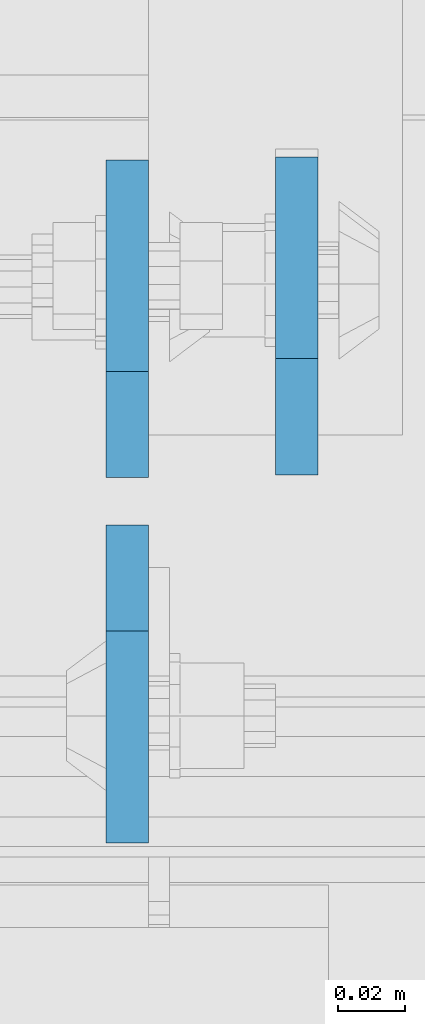
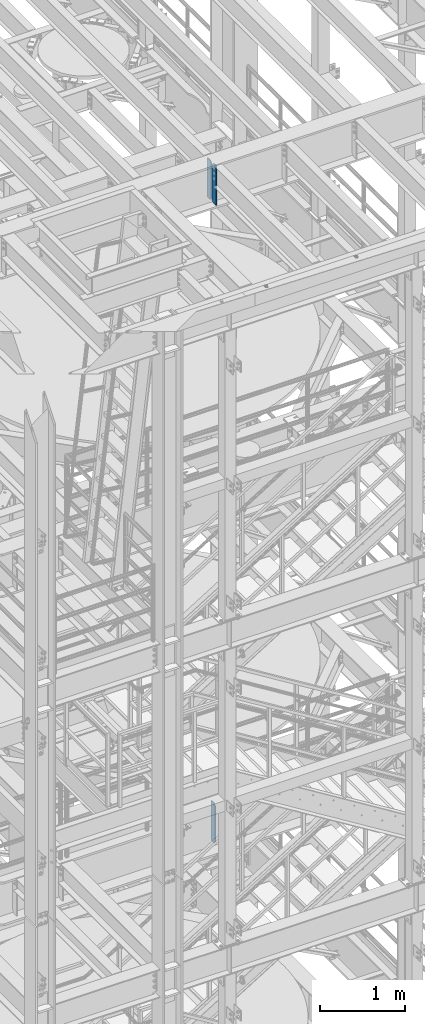
# One storey, part 1494 of 1876: 3 plates, 2 elements without a shape of their own.
"""IFC2X3 building model written with IfcOpenShell, lengths in millimetres."""

from ifc_helpers import new_model, si_unit, frame, origin_with_axes, place, context, subcontext, project, spatial, faceted_brep, material, type_object, element, aggregate, save


model = new_model("IFC2X3")

# Units and contexts
model_context = context("Model", 3, precision=1e-05, world=origin_with_axes())
body_context = subcontext(model_context, "Body", "Model", "MODEL_VIEW")
ifc_project = project(units=[si_unit("LENGTHUNIT", "METRE", prefix="MILLI"), si_unit("AREAUNIT", "SQUARE_METRE"), si_unit("VOLUMEUNIT", "CUBIC_METRE"), si_unit("MASSUNIT", "GRAM", prefix="KILO"), si_unit("TIMEUNIT", "SECOND"), si_unit("PLANEANGLEUNIT", "RADIAN"), si_unit("SOLIDANGLEUNIT", "STERADIAN"), si_unit("THERMODYNAMICTEMPERATUREUNIT", "DEGREE_CELSIUS"), si_unit("LUMINOUSINTENSITYUNIT", "LUMEN")], contexts=[model_context])

# Site, building, storey
site_placement = place(None, origin_with_axes())
site = spatial("IfcSite", under=ifc_project, at=site_placement, CompositionType="ELEMENT")
building_placement = place(site_placement, origin_with_axes())
building = spatial("IfcBuilding", under=site, at=building_placement, Name="Undefined", CompositionType="ELEMENT")
storey_placement = place(building_placement, origin_with_axes())
storey = spatial("IfcBuildingStorey", under=building, at=storey_placement, Name="Undefined", CompositionType="ELEMENT", Elevation=0.0)

# Assembly, plate
assembly_1_placement = place(storey_placement, origin_with_axes())
assembly_1 = element("IfcElementAssembly", 1, at=assembly_1_placement, inside=storey, Name="BEAM", AssemblyPlace="NOTDEFINED", PredefinedType="RIGID_FRAME")
ifc_material = material(Name="STEEL/A36")
plate_type = type_object("IfcPlateType", PredefinedType="NOTDEFINED")
plate_1_placement = place(assembly_1_placement, frame((3851.27499990463, -4564.0625, 12709.525), z_axis=(0.0, 0.0, 1.0), x_axis=(0.0, 1.0, 0.0)))
plate_1 = element("IfcPlate", 2, at=plate_1_placement, type_object=plate_type, material=ifc_material, Name="PLATE", context=body_context, shape_type="Brep", body=[
    faceted_brep([(0.0, -6.34999999999991, 34.9249992370605), (0.0, -6.35000000000036, 538.162475585938), (0.0, 6.35000000000036, 538.162475585938), (0.0, 6.34999999999991, 34.9249992370605), (34.9249992370605, -6.34999999999991, 573.087524414062), (34.9249992370605, 6.34999999999991, 573.087524414062), (95.25, -6.34999999999991, 573.087524414062), (95.25, 6.34999999999991, 573.087524414062), (95.25, -6.35000000000036, 0.0), (95.25, 6.35000000000036, 0.0), (34.9249992370605, -6.34999999999991, 0.0), (34.9249992370605, 6.34999999999991, 0.0)], [[[0, 1, 2, 3]], [[1, 4, 5, 2]], [[4, 6, 7, 5]], [[6, 8, 9, 7]], [[8, 10, 11, 9]], [[10, 0, 3, 11]], [[5, 7, 9, 11, 3, 2]], [[10, 8, 6, 4, 1, 0]]]),
])
aggregate(assembly_1, [plate_1])

# Assembly, plates
assembly_2_placement = place(storey_placement, origin_with_axes())
assembly_2 = element("IfcElementAssembly", 3, at=assembly_2_placement, inside=storey, Name="BEAM", AssemblyPlace="NOTDEFINED", PredefinedType="RIGID_FRAME")
plate_2_placement = place(assembly_2_placement, frame((3800.47499990463, -4579.14375, 21959.8875), z_axis=(0.0, 0.0, 1.0), x_axis=(0.0, -1.0, 0.0)))
plate_2 = element("IfcPlate", 4, at=plate_2_placement, type_object=plate_type, material=ifc_material, Name="PLATE", context=body_context, shape_type="Brep", body=[
    faceted_brep([(0.0, -6.34999999999991, 31.75), (0.0, -6.35000000000036, 538.162475585938), (0.0, 6.35000000000036, 538.162475585938), (0.0, 6.34999999999991, 31.75), (31.75, -6.35000000000036, 569.912475585938), (31.75, 6.35000000000036, 569.912475585938), (95.25, -6.35000000000036, 569.912475585938), (95.25, 6.35000000000036, 569.912475585938), (95.25, -6.35000000000036, 0.0), (95.25, 6.35000000000036, 0.0), (31.75, -6.34999999999991, 0.0), (31.75, 6.34999999999991, 0.0)], [[[0, 1, 2, 3]], [[1, 4, 5, 2]], [[4, 6, 7, 5]], [[6, 8, 9, 7]], [[8, 10, 11, 9]], [[10, 0, 3, 11]], [[5, 7, 9, 11, 3, 2]], [[10, 8, 6, 4, 1, 0]]]),
])
plate_3_placement = place(assembly_2_placement, frame((3800.47499990463, -4564.85625, 21959.8875), z_axis=(0.0, 0.0, 1.0), x_axis=(0.0, 1.0, 0.0)))
plate_3 = element("IfcPlate", 5, at=plate_3_placement, type_object=plate_type, material=ifc_material, Name="PLATE", context=body_context, shape_type="Brep", body=[
    faceted_brep([(0.0, -6.34999999999991, 31.75), (0.0, -6.35000000000036, 538.162475585938), (0.0, 6.35000000000036, 538.162475585938), (0.0, 6.34999999999991, 31.75), (31.75, -6.35000000000036, 569.912475585938), (31.75, 6.35000000000036, 569.912475585938), (95.25, -6.35000000000036, 569.912475585938), (95.25, 6.35000000000036, 569.912475585938), (95.25, -6.35000000000036, 0.0), (95.25, 6.35000000000036, 0.0), (31.75, -6.34999999999991, 0.0), (31.75, 6.34999999999991, 0.0)], [[[0, 1, 2, 3]], [[1, 4, 5, 2]], [[4, 6, 7, 5]], [[6, 8, 9, 7]], [[8, 10, 11, 9]], [[10, 0, 3, 11]], [[5, 7, 9, 11, 3, 2]], [[10, 8, 6, 4, 1, 0]]]),
])
aggregate(assembly_2, [plate_2, plate_3])

save(model, "model.ifc")
